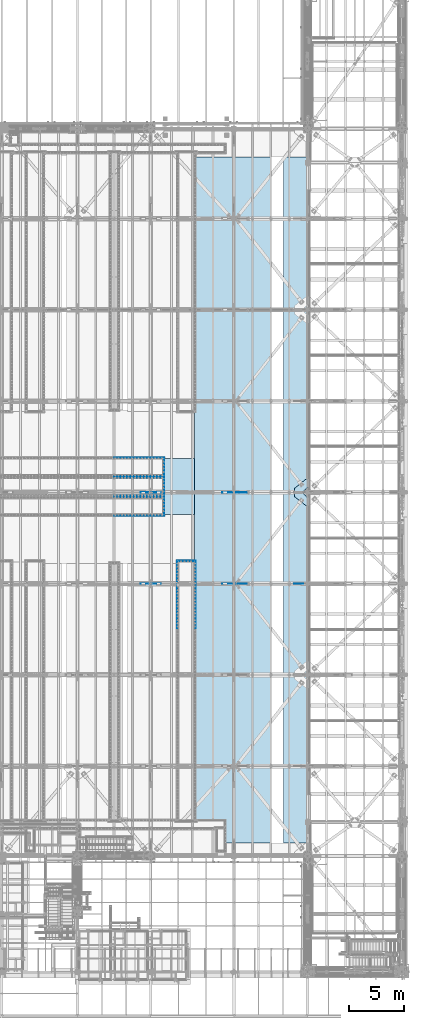
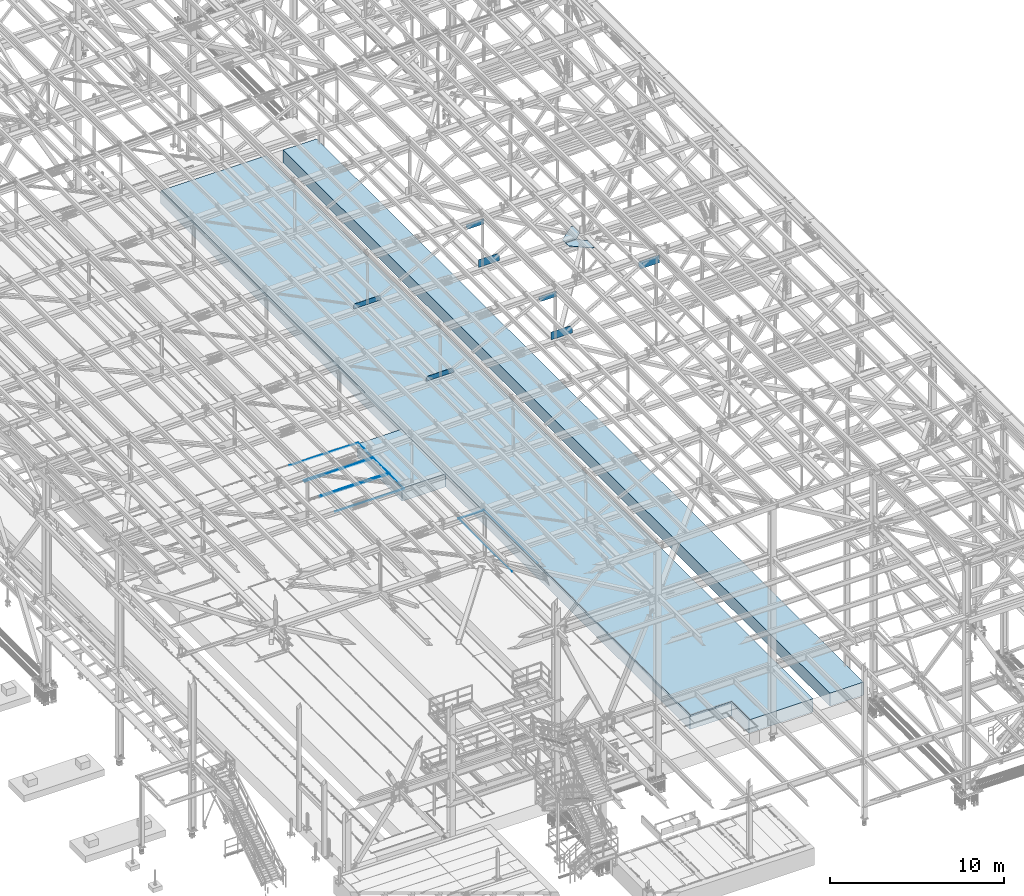
# One storey, part 2983 of 3843: 21 plates, 3 slabs, 23 elements without a shape of their own.
"""IFC2X3 building model written with IfcOpenShell, lengths in millimetres."""

from ifc_helpers import new_model, si_unit, frame, origin_with_axes, place, context, subcontext, project, spatial, faceted_brep, material, type_object, element, aggregate, save


model = new_model("IFC2X3")

# Units and contexts
model_context = context("Model", 3, precision=1e-05, world=origin_with_axes())
body_context = subcontext(model_context, "Body", "Model", "MODEL_VIEW")
ifc_project = project(units=[si_unit("LENGTHUNIT", "METRE", prefix="MILLI"), si_unit("AREAUNIT", "SQUARE_METRE"), si_unit("VOLUMEUNIT", "CUBIC_METRE"), si_unit("MASSUNIT", "GRAM", prefix="KILO"), si_unit("TIMEUNIT", "SECOND"), si_unit("PLANEANGLEUNIT", "RADIAN"), si_unit("SOLIDANGLEUNIT", "STERADIAN"), si_unit("THERMODYNAMICTEMPERATUREUNIT", "DEGREE_CELSIUS"), si_unit("LUMINOUSINTENSITYUNIT", "LUMEN")], contexts=[model_context])

# Site, building, storey
site_placement = place(None, origin_with_axes())
site = spatial("IfcSite", under=ifc_project, at=site_placement, CompositionType="ELEMENT")
building_placement = place(site_placement, origin_with_axes())
building = spatial("IfcBuilding", under=site, at=building_placement, Name="Undefined", CompositionType="ELEMENT")
storey_placement = place(building_placement, origin_with_axes())
storey = spatial("IfcBuildingStorey", under=building, at=storey_placement, Name="Undefined", CompositionType="ELEMENT", Elevation=0.0)

# Assembly, plate
assembly_1_placement = place(storey_placement, origin_with_axes())
assembly_1 = element("IfcElementAssembly", 1, at=assembly_1_placement, inside=storey, Name="EMBED_ANGLE", AssemblyPlace="NOTDEFINED", PredefinedType="RIGID_FRAME")
ifc_material_1 = material(Name="STEEL/A36")
plate_type_1 = type_object("IfcPlateType", PredefinedType="NOTDEFINED")
plate_1_placement = place(assembly_1_placement, frame((63869.062, 60391.2939999994, 30480.0000003815), z_axis=(0.0, 1.0, 0.0), x_axis=(0.0, 0.0, -1.0)))
plate_1 = element("IfcPlate", 2, at=plate_1_placement, type_object=plate_type_1, material=ifc_material_1, Name="PLATE", context=body_context, shape_type="Brep", body=[
    faceted_brep([(20.6375000381231, -6.35000000004948, 2.5465851649642e-11), (0.0, -6.3499999046162, 0.0), (0.0, 6.34999999999854, 12.6999998092651), (25.3999996185303, 6.34999999999854, 12.6999999977998), (25.3999996185303, -1.58750000000146, 4.76249999779975), (25.3999996185266, -1.58750000000146, 1697.41849965054), (20.6374996185259, -6.34999999999854, 1702.18100000139), (3.81471181754023e-07, -6.34999999999854, 1702.181), (3.78626282326877e-07, 6.34999999999854, 1689.48099965054), (25.3999996185303, 6.34999999999854, 1689.48099965054)], [[[0, 1, 2, 3, 4]], [[0, 4, 5, 6]], [[1, 0, 6, 7]], [[2, 1, 7, 8]], [[3, 2, 8, 9]], [[4, 3, 9, 5]], [[8, 7, 6, 5, 9]]]),
])
aggregate(assembly_1, [plate_1])

assembly_2_placement = place(storey_placement, origin_with_axes())
assembly_2 = element("IfcElementAssembly", 3, at=assembly_2_placement, inside=storey, Name="EMBED_ANGLE", AssemblyPlace="NOTDEFINED", PredefinedType="RIGID_FRAME")
plate_2_placement = place(assembly_2_placement, frame((59303.4115875649, 60397.6439999965, 30480.0000025529), z_axis=(0.999999999868683, 0.0, 1.62059999202029e-05), x_axis=(1.62059999200984e-05, 0.0, -0.999999999868683)))
plate_2 = element("IfcPlate", 4, at=plate_2_placement, type_object=plate_type_1, material=ifc_material_1, Name="PLATE", context=body_context, shape_type="Brep", body=[
    faceted_brep([(0.0, -6.3499999046162, 0.0), (7.27595761418343e-12, 6.3499999046162, 0.0), (25.3999999999942, 6.34999999994034, 2.91038304567337e-11), (25.3999996185921, -1.5874999999869, 7.27595761418343e-11), (20.6375000381231, -6.35000000004948, 2.5465851649642e-11), (25.4740150924117, -1.5874999999869, 4567.23749942215), (20.7115934803587, -6.34999999999854, 4572.00018920841), (0.0740914578454976, -6.34999999999854, 4572.00058593692), (0.0738856454336201, 6.34999999999854, 4559.30041105553), (25.4738855178657, 6.34999999999854, 4559.29999942322)], [[[0, 1, 2, 3, 4]], [[4, 3, 5, 6]], [[0, 4, 6, 7]], [[1, 0, 7, 8]], [[2, 1, 8, 9]], [[3, 2, 9, 5]], [[8, 7, 6, 5, 9]]]),
])
aggregate(assembly_2, [plate_2])

assembly_3_placement = place(storey_placement, origin_with_axes())
assembly_3 = element("IfcElementAssembly", 5, at=assembly_3_placement, inside=storey, Name="EMBED_ANGLE", AssemblyPlace="NOTDEFINED", PredefinedType="RIGID_FRAME")
plate_3_placement = place(assembly_3_placement, frame((59303.4115875649, 62087.1249999965, 30480.0000025529), z_axis=(0.999999999868683, 0.0, 1.62059999202029e-05), x_axis=(1.62059999200984e-05, 0.0, -0.999999999868683)))
plate_3 = element("IfcPlate", 6, at=plate_3_placement, type_object=plate_type_1, material=ifc_material_1, Name="PLATE", context=body_context, shape_type="Brep", body=[
    faceted_brep([(25.3999996185303, -6.34999999999491, 2.91038304567337e-11), (0.0, -6.3499999046162, 0.0), (7.27595761418343e-12, 6.3499999046162, 0.0), (20.6374996185295, 6.35000000000218, -7.27595761418343e-12), (25.3999996185921, 1.58750000000146, 7.27595761418343e-11), (25.4740192314966, 1.58750000000146, 4567.23750020325), (25.4738855178766, -6.34999999999854, 4559.30000020438), (0.073885645444534, -6.34999999999854, 4559.30041183668), (0.0740914578454976, 6.34999999999854, 4572.00058593692), (20.7115934803733, 6.34999999999854, 4572.00018920841)], [[[0, 1, 2, 3, 4]], [[0, 4, 5, 6]], [[1, 0, 6, 7]], [[2, 1, 7, 8]], [[3, 2, 8, 9]], [[4, 3, 9, 5]], [[8, 7, 6, 5, 9]]]),
])
aggregate(assembly_3, [plate_3])

assembly_4_placement = place(storey_placement, origin_with_axes())
assembly_4 = element("IfcElementAssembly", 7, at=assembly_4_placement, inside=storey, Name="EMBED_ANGLE", AssemblyPlace="NOTDEFINED", PredefinedType="RIGID_FRAME")
plate_4_placement = place(assembly_4_placement, frame((63869.062, 58587.8939999994, 30480.0000003815), z_axis=(0.0, 1.0, 0.0), x_axis=(0.0, 0.0, -1.0)))
plate_4 = element("IfcPlate", 8, at=plate_4_placement, type_object=plate_type_1, material=ifc_material_1, Name="PLATE", context=body_context, shape_type="Brep", body=[
    faceted_brep([(20.6375000381231, -6.35000000004948, 2.5465851649642e-11), (0.0, -6.3499999046162, 0.0), (0.0, 6.34999999999854, 12.6999998092651), (25.3999996185303, 6.34999999999854, 12.6999999977998), (25.3999996185303, -1.58750000000146, 4.76249999779975), (25.3999996185266, -1.58750000000146, 1697.41849965054), (20.6374996185259, -6.34999999999854, 1702.18100000139), (3.81471181754023e-07, -6.34999999999854, 1702.181), (3.78626282326877e-07, 6.34999999999854, 1689.48099965054), (25.3999996185303, 6.34999999999854, 1689.48099965054)], [[[0, 1, 2, 3, 4]], [[0, 4, 5, 6]], [[1, 0, 6, 7]], [[2, 1, 7, 8]], [[3, 2, 8, 9]], [[4, 3, 9, 5]], [[8, 7, 6, 5, 9]]]),
])
aggregate(assembly_4, [plate_4])

assembly_5_placement = place(storey_placement, origin_with_axes())
assembly_5 = element("IfcElementAssembly", 9, at=assembly_5_placement, inside=storey, Name="EMBED_ANGLE", AssemblyPlace="NOTDEFINED", PredefinedType="RIGID_FRAME")
plate_5_placement = place(assembly_5_placement, frame((59303.4115875649, 58594.2439999965, 30480.0000025529), z_axis=(0.999999999868683, 0.0, 1.62059999202029e-05), x_axis=(1.62059999200984e-05, 0.0, -0.999999999868683)))
plate_5 = element("IfcPlate", 10, at=plate_5_placement, type_object=plate_type_1, material=ifc_material_1, Name="PLATE", context=body_context, shape_type="Brep", body=[
    faceted_brep([(0.0, -6.3499999046162, 0.0), (7.27595761418343e-12, 6.3499999046162, 0.0), (25.3999999999942, 6.34999999994034, 2.91038304567337e-11), (25.3999996185921, -1.5874999999869, 7.27595761418343e-11), (20.6375000381231, -6.35000000004948, 2.5465851649642e-11), (25.4740150924117, -1.5874999999869, 4567.23749942215), (20.7115934803587, -6.34999999999854, 4572.00018920841), (0.0740914578454976, -6.34999999999854, 4572.00058593692), (0.0738856454336201, 6.34999999999854, 4559.30041105553), (25.4738855178657, 6.34999999999854, 4559.29999942322)], [[[0, 1, 2, 3, 4]], [[4, 3, 5, 6]], [[0, 4, 6, 7]], [[1, 0, 7, 8]], [[2, 1, 8, 9]], [[3, 2, 9, 5]], [[8, 7, 6, 5, 9]]]),
])
aggregate(assembly_5, [plate_5])

assembly_6_placement = place(storey_placement, origin_with_axes())
assembly_6 = element("IfcElementAssembly", 11, at=assembly_6_placement, inside=storey, Name="EMBED_ANGLE", AssemblyPlace="NOTDEFINED", PredefinedType="RIGID_FRAME")
plate_6_placement = place(assembly_6_placement, frame((59303.4115875649, 60283.7249999965, 30480.0000025529), z_axis=(0.999999999868683, 0.0, 1.62059999202029e-05), x_axis=(1.62059999200984e-05, 0.0, -0.999999999868683)))
plate_6 = element("IfcPlate", 12, at=plate_6_placement, type_object=plate_type_1, material=ifc_material_1, Name="PLATE", context=body_context, shape_type="Brep", body=[
    faceted_brep([(25.3999996185303, -6.34999999999491, 2.91038304567337e-11), (0.0, -6.3499999046162, 0.0), (7.27595761418343e-12, 6.3499999046162, 0.0), (20.6374996185295, 6.35000000000218, -7.27595761418343e-12), (25.3999996185921, 1.58750000000146, 7.27595761418343e-11), (25.4740192314966, 1.58750000000146, 4567.23750020325), (25.4738855178766, -6.34999999999854, 4559.30000020438), (0.073885645444534, -6.34999999999854, 4559.30041183668), (0.0740914578454976, 6.34999999999854, 4572.00058593692), (20.7115934803733, 6.34999999999854, 4572.00018920841)], [[[0, 1, 2, 3, 4]], [[0, 4, 5, 6]], [[1, 0, 6, 7]], [[2, 1, 7, 8]], [[3, 2, 8, 9]], [[4, 3, 9, 5]], [[8, 7, 6, 5, 9]]]),
])
aggregate(assembly_6, [plate_6])

assembly_7_placement = place(storey_placement, origin_with_axes())
assembly_7 = element("IfcElementAssembly", 13, at=assembly_7_placement, inside=storey, Name="EMBED_ANGLE", AssemblyPlace="NOTDEFINED", PredefinedType="RIGID_FRAME")
plate_7_placement = place(assembly_7_placement, frame((63869.0615883789, 56784.8750000029, 30480.0000003815), z_axis=(0.0, 1.0, 0.0), x_axis=(0.0, 0.0, -1.0)))
plate_7 = element("IfcPlate", 14, at=plate_7_placement, type_object=plate_type_1, material=ifc_material_1, Name="PLATE", context=body_context, shape_type="Brep", body=[
    faceted_brep([(20.6375000381231, -6.35000000004948, 2.5465851649642e-11), (0.0, -6.3499999046162, 0.0), (0.0, 6.34999999999854, 12.6999998092651), (25.3999996185303, 6.34999999999854, 12.6999999977998), (25.3999996185303, -1.58750000000146, 4.76249999779975), (25.3999996185266, -1.58750000000146, 1697.41849965054), (20.6374996185259, -6.34999999999854, 1702.18100000139), (3.81471181754023e-07, -6.34999999999854, 1702.181), (3.78626282326877e-07, 6.34999999999854, 1689.48099965054), (25.3999996185303, 6.34999999999854, 1689.48099965054)], [[[0, 1, 2, 3, 4]], [[0, 4, 5, 6]], [[1, 0, 6, 7]], [[2, 1, 7, 8]], [[3, 2, 8, 9]], [[4, 3, 9, 5]], [[8, 7, 6, 5, 9]]]),
])
aggregate(assembly_7, [plate_7])

assembly_8_placement = place(storey_placement, origin_with_axes())
assembly_8 = element("IfcElementAssembly", 15, at=assembly_8_placement, inside=storey, Name="EMBED_ANGLE", AssemblyPlace="NOTDEFINED", PredefinedType="RIGID_FRAME")
plate_8_placement = place(assembly_8_placement, frame((65056.6071409332, 52635.1500664063, 30480.0000003815), z_axis=(1.0, 0.0, 0.0), x_axis=(0.0, 0.0, -1.0)))
plate_8 = element("IfcPlate", 16, at=plate_8_placement, type_object=plate_type_1, material=ifc_material_1, Name="PLATE", context=body_context, shape_type="Brep", body=[
    faceted_brep([(3.81471181754023e-07, 6.34999999555293, 1701.76888183631), (3.78615368390456e-07, -6.35000000440778, 1689.02774962055), (25.3999996185303, -6.35000000440778, 1689.02774962055), (25.4000000789601, 1.58749890214676, 1696.99095680546), (20.6375003659959, 6.34999999555293, 1701.76888183631), (25.3999996185303, -6.3500000000131, 12.6685752134799), (25.3999996198145, 1.58727214156534, 4.73130159008724), (20.6374996185295, 6.35000000000218, -7.27595761418343e-12), (7.27595761418343e-12, 6.3499999046162, 0.0), (2.84126144833863e-09, -6.3500000000131, 12.6685752134799)], [[[0, 1, 2, 3, 4]], [[3, 2, 5, 6]], [[4, 3, 6, 7]], [[0, 4, 7, 8]], [[1, 0, 8, 9]], [[2, 1, 9, 5]], [[8, 7, 6, 5, 9]]]),
])
aggregate(assembly_8, [plate_8])

assembly_9_placement = place(storey_placement, origin_with_axes())
assembly_9 = element("IfcElementAssembly", 17, at=assembly_9_placement, inside=storey, Name="EMBED_ANGLE", AssemblyPlace="NOTDEFINED", PredefinedType="RIGID_FRAME")
plate_9_placement = place(assembly_9_placement, frame((59303.4111759438, 56791.225, 30480.0000025529), z_axis=(0.999999999868683, 0.0, 1.62059999202029e-05), x_axis=(1.62059999200984e-05, 0.0, -0.999999999868683)))
plate_9 = element("IfcPlate", 18, at=plate_9_placement, type_object=plate_type_1, material=ifc_material_1, Name="PLATE", context=body_context, shape_type="Brep", body=[
    faceted_brep([(0.0, -6.3499999046162, 0.0), (7.27595761418343e-12, 6.3499999046162, 0.0), (25.3999999999942, 6.34999999994034, 2.91038304567337e-11), (25.3999996185921, -1.5874999999869, 7.27595761418343e-11), (20.6375000381231, -6.35000000004948, 2.5465851649642e-11), (25.4740150924117, -1.5874999999869, 4567.23749942215), (20.7115934803587, -6.34999999999854, 4572.00018920841), (0.0740914578454976, -6.34999999999854, 4572.00058593692), (0.0738856454336201, 6.34999999999854, 4559.30041105553), (25.4738855178657, 6.34999999999854, 4559.29999942322)], [[[0, 1, 2, 3, 4]], [[4, 3, 5, 6]], [[0, 4, 6, 7]], [[1, 0, 7, 8]], [[2, 1, 8, 9]], [[3, 2, 9, 5]], [[8, 7, 6, 5, 9]]]),
])
aggregate(assembly_9, [plate_9])

assembly_10_placement = place(storey_placement, origin_with_axes())
assembly_10 = element("IfcElementAssembly", 19, at=assembly_10_placement, inside=storey, Name="EMBED_ANGLE", AssemblyPlace="NOTDEFINED", PredefinedType="RIGID_FRAME")
plate_10_placement = place(assembly_10_placement, frame((59303.4111759438, 58480.706, 30480.0000025529), z_axis=(0.999999999868683, 0.0, 1.62059999202029e-05), x_axis=(1.62059999200984e-05, 0.0, -0.999999999868683)))
plate_10 = element("IfcPlate", 20, at=plate_10_placement, type_object=plate_type_1, material=ifc_material_1, Name="PLATE", context=body_context, shape_type="Brep", body=[
    faceted_brep([(25.3999996185303, -6.34999999999491, 2.91038304567337e-11), (0.0, -6.3499999046162, 0.0), (7.27595761418343e-12, 6.3499999046162, 0.0), (20.6374996185295, 6.35000000000218, -7.27595761418343e-12), (25.3999996185921, 1.58750000000146, 7.27595761418343e-11), (25.4740192314966, 1.58750000000146, 4567.23750020325), (25.4738855178766, -6.34999999999854, 4559.30000020438), (0.073885645444534, -6.34999999999854, 4559.30041183668), (0.0740914578454976, 6.34999999999854, 4572.00058593692), (20.7115934803733, 6.34999999999854, 4572.00018920841)], [[[0, 1, 2, 3, 4]], [[0, 4, 5, 6]], [[1, 0, 6, 7]], [[2, 1, 7, 8]], [[3, 2, 8, 9]], [[4, 3, 9, 5]], [[8, 7, 6, 5, 9]]]),
])
aggregate(assembly_10, [plate_10])

assembly_11_placement = place(storey_placement, origin_with_axes())
assembly_11 = element("IfcElementAssembly", 21, at=assembly_11_placement, inside=storey, Name="EMBED_ANGLE", AssemblyPlace="NOTDEFINED", PredefinedType="RIGID_FRAME")
plate_11_placement = place(assembly_11_placement, frame((66751.9620305816, 52641.5, 30480.0000003815), z_axis=(0.0, -1.0, 0.0), x_axis=(0.0, 0.0, -1.0)))
plate_11 = element("IfcPlate", 22, at=plate_11_placement, type_object=plate_type_1, material=ifc_material_1, Name="PLATE", context=body_context, shape_type="Brep", body=[
    faceted_brep([(3.81471181754023e-07, 6.34999996374245, 6184.9), (3.81471181754023e-07, -6.35000003625464, 6184.90000000001), (25.3999996185303, -6.35000003625464, 6184.90000000001), (25.3999995799313, 1.58750029788644, 6184.90000609555), (20.6374984696922, 6.34999996374245, 6184.9), (25.3999996185303, -6.35000000006403, 12.7112641409767), (25.3999996185012, 1.58746944241284, 4.80682773893932), (20.6374996185295, 6.35000000000218, -7.27595761418343e-12), (7.27595761418343e-12, 6.3499999046162, 0.0), (7.8580342233181e-10, -6.35000000006403, 12.7112641409767)], [[[0, 1, 2, 3, 4]], [[3, 2, 5, 6]], [[4, 3, 6, 7]], [[0, 4, 7, 8]], [[1, 0, 8, 9]], [[2, 1, 9, 5]], [[8, 7, 6, 5, 9]]]),
])
aggregate(assembly_11, [plate_11])

assembly_12_placement = place(storey_placement, origin_with_axes())
assembly_12 = element("IfcElementAssembly", 23, at=assembly_12_placement, inside=storey, Name="EMBED_ANGLE", AssemblyPlace="NOTDEFINED", PredefinedType="RIGID_FRAME")
plate_12_placement = place(assembly_12_placement, frame((65062.957142635, 52641.5000664063, 30480.0000003815), z_axis=(-5.10699999722418e-06, -0.999999999986959, 0.0), x_axis=(0.0, 0.0, -1.0)))
plate_12 = element("IfcPlate", 24, at=plate_12_placement, type_object=plate_type_1, material=ifc_material_1, Name="PLATE", context=body_context, shape_type="Brep", body=[
    faceted_brep([(25.3999996185303, 6.34999998807325, 6184.89987113706), (3.81471181754023e-07, 6.34999998807325, 6184.89987113706), (3.81471181754023e-07, -6.35000001190929, 6184.89987113703), (20.637498469714, -6.35000001190929, 6184.89987113703), (25.3999996185521, -1.58750068734662, 6184.89987113704), (25.3999996185303, 6.34999999996217, 12.731334147873), (7.8580342233181e-10, 6.34999999996217, 12.731334147873), (0.0, -6.3499999046162, 0.0), (20.6375000381231, -6.35000000004948, 2.5465851649642e-11), (25.3999996185303, -1.61906264965364, 4.76235011019162)], [[[0, 1, 2, 3, 4]], [[1, 0, 5, 6]], [[2, 1, 6, 7]], [[3, 2, 7, 8]], [[4, 3, 8, 9]], [[0, 4, 9, 5]], [[8, 7, 6, 5, 9]]]),
])
aggregate(assembly_12, [plate_12])

assembly_13_placement = place(storey_placement, origin_with_axes())
assembly_13 = element("IfcElementAssembly", 25, at=assembly_13_placement, inside=storey, Name="PLATE", AssemblyPlace="NOTDEFINED", PredefinedType="RIGID_FRAME")
ifc_material_2 = material(Name="STEEL/A572-50")
plate_type_2 = type_object("IfcPlateType", PredefinedType="NOTDEFINED")
plate_13_placement = place(assembly_13_placement, frame((77008.0375222877, 59397.8999848818, 42232.2625), z_axis=(-1.0, 0.0, 0.0), x_axis=(0.0, 1.0, 0.0)))
plate_13 = element("IfcPlate", 26, at=plate_13_placement, type_object=plate_type_2, material=ifc_material_2, Name="PLATE", context=body_context, shape_type="Brep", body=[
    faceted_brep([(0.0, -14.2874999999985, 0.0), (-475.456250002258, -14.2874999999985, 477.837502193986), (-475.456250002258, 14.2874999999985, 477.837502193986), (0.0, 14.2874999999985, 0.0), (-475.456250002258, -14.2874999999985, 1214.4375021945), (-475.456250002258, 14.2874999999985, 1214.4375021945), (-125.919147861619, -14.2874999999985, 1214.43750308026), (-125.919147861619, 14.2874999999985, 1214.43750308026), (736.600000090519, -14.2874999999985, 147.637499993114), (736.600000090519, 14.2874999999985, 147.637499993114), (736.599999940488, -14.2874999999985, 0.0), (736.599999940488, 14.2874999999985, 0.0)], [[[0, 1, 2, 3]], [[1, 4, 5, 2]], [[4, 6, 7, 5]], [[6, 8, 9, 7]], [[8, 10, 11, 9]], [[10, 0, 3, 11]], [[5, 7, 9, 11, 3, 2]], [[10, 8, 6, 4, 1, 0]]]),
])
aggregate(assembly_13, [plate_13])

assembly_14_placement = place(storey_placement, origin_with_axes())
assembly_14 = element("IfcElementAssembly", 27, at=assembly_14_placement, inside=storey, Name="PLATE", AssemblyPlace="NOTDEFINED", PredefinedType="RIGID_FRAME")
plate_14_placement = place(assembly_14_placement, frame((77008.037519207, 58432.6999848772, 42232.2625), z_axis=(-1.0, 0.0, 0.0), x_axis=(0.0, -1.0, 0.0)))
plate_14 = element("IfcPlate", 28, at=plate_14_placement, type_object=plate_type_2, material=ifc_material_2, Name="PLATE", context=body_context, shape_type="Brep", body=[
    faceted_brep([(0.0, -14.2874999999985, 0.0), (-475.456250002258, -14.2874999999985, 477.837502193986), (-475.456250002258, 14.2874999999985, 477.837502193986), (0.0, 14.2874999999985, 0.0), (-475.456250002258, -14.2874999999985, 1214.4375021945), (-475.456250002258, 14.2874999999985, 1214.4375021945), (-103.221274751806, -14.2874999999985, 1214.43749780451), (-103.221274751806, 14.2874999999985, 1214.43749780451), (736.600000090519, -14.2874999999985, 147.637499993114), (736.600000090519, 14.2874999999985, 147.637499993114), (736.599999940488, -14.2874999999985, 0.0), (736.599999940488, 14.2874999999985, 0.0)], [[[0, 1, 2, 3]], [[1, 4, 5, 2]], [[4, 6, 7, 5]], [[6, 8, 9, 7]], [[8, 10, 11, 9]], [[10, 0, 3, 11]], [[5, 7, 9, 11, 3, 2]], [[10, 8, 6, 4, 1, 0]]]),
])
aggregate(assembly_14, [plate_14])

assembly_15_placement = place(storey_placement, origin_with_axes())
assembly_15 = element("IfcElementAssembly", 29, at=assembly_15_placement, inside=storey, Name="BEAM", AssemblyPlace="NOTDEFINED", PredefinedType="RIGID_FRAME")
plate_type_3 = type_object("IfcPlateType", PredefinedType="NOTDEFINED")
plate_15_placement = place(assembly_15_placement, frame((71423.0407854026, 58915.3, 42532.3048757002), z_axis=(0.000189087000020663, 0.0, 0.999999982123053), x_axis=(-0.999999982123053, 0.0, 0.000189087000025738)))
plate_15 = element("IfcPlate", 30, at=plate_15_placement, type_object=plate_type_3, material=ifc_material_2, Name="PLATE", context=body_context, shape_type="Brep", body=[
    faceted_brep([(0.0, -9.52500000000146, 0.0), (-1.19325704872608e-09, -9.52500000000146, 272.018172355572), (-1.19325704872608e-09, 9.52500000000146, 272.018172355572), (0.0, 9.52500000000146, 0.0), (150.207742872095, -9.52500000000146, 537.236336314461), (150.207742872095, 9.52500000000146, 537.236336314461), (1398.51735042044, -9.52500000000146, 537.236336310845), (1398.51735042044, 9.52500000000146, 537.236336310845), (1398.51735042283, -9.52500000000146, -4.06726030632854e-09), (1398.51735042283, 9.52500000000146, -4.06726030632854e-09)], [[[0, 1, 2, 3]], [[1, 4, 5, 2]], [[4, 6, 7, 5]], [[6, 8, 9, 7]], [[8, 0, 3, 9]], [[5, 7, 9, 3, 2]], [[8, 6, 4, 1, 0]]]),
])
aggregate(assembly_15, [plate_15])

assembly_16_placement = place(storey_placement, origin_with_axes())
assembly_16 = element("IfcElementAssembly", 31, at=assembly_16_placement, inside=storey, Name="BEAM", AssemblyPlace="NOTDEFINED", PredefinedType="RIGID_FRAME")
plate_type_4 = type_object("IfcPlateType", PredefinedType="NOTDEFINED")
plate_16_placement = place(assembly_16_placement, frame((70370.2239296506, 58915.3, 45840.8628900239), z_axis=(0.0210423920075118, 0.0, -0.999778584356858), x_axis=(-0.999778584356858, 0.0, -0.0210423920075088)))
plate_16 = element("IfcPlate", 32, at=plate_16_placement, type_object=plate_type_4, material=ifc_material_2, Name="PLATE", context=body_context, shape_type="Brep", body=[
    faceted_brep([(0.0, -9.52500000000146, 0.0), (7.49736213505093, -9.52500000000146, 378.809671376701), (7.49736213505093, 9.52500000000146, 378.809671376701), (0.0, 9.52500000000146, 0.0), (1072.73514739941, -9.52500000000146, 356.387583692478), (1072.73514739941, 9.52500000000146, 356.387583692478), (1178.64157550852, -9.52500000000146, 125.520023338257), (1178.64157550852, 9.52500000000146, 125.520023338257), (1178.64157550936, -9.52500000000146, -8.94942786544561e-09), (1178.64157550936, 9.52500000000146, -8.94942786544561e-09)], [[[0, 1, 2, 3]], [[1, 4, 5, 2]], [[4, 6, 7, 5]], [[6, 8, 9, 7]], [[8, 0, 3, 9]], [[5, 7, 9, 3, 2]], [[8, 6, 4, 1, 0]]]),
])
aggregate(assembly_16, [plate_16])

# Assembly, plates
assembly_17_placement = place(storey_placement, origin_with_axes())
assembly_17 = element("IfcElementAssembly", 33, at=assembly_17_placement, inside=storey, Name="BEAM", AssemblyPlace="NOTDEFINED", PredefinedType="RIGID_FRAME")
plate_17_placement = place(assembly_17_placement, frame((70370.2266121063, 50558.7, 45836.8400614558), z_axis=(0.0209237229988212, 0.0, -0.999781074943844), x_axis=(-0.999781074943844, 0.0, -0.0209237229988253)))
plate_17 = element("IfcPlate", 34, at=plate_17_placement, type_object=plate_type_4, material=ifc_material_2, Name="PLATE", context=body_context, shape_type="Brep", body=[
    faceted_brep([(0.0, -9.52500000000146, 0.0), (7.45257887804473, -9.52500000000146, 378.690789820255), (7.45257887804473, 9.52500000000146, 378.690789820255), (0.0, 9.52500000000146, 0.0), (1072.71180081816, -9.52500000000146, 356.394743734098), (1072.71180081816, 9.52500000000146, 356.394743734098), (1178.6238194461, -9.52500000000146, 125.52974722629), (1178.6238194461, 9.52500000000146, 125.52974722629), (1178.6238194473, -9.52500000000146, 1.10594555735588e-08), (1178.6238194473, 9.52500000000146, 1.10594555735588e-08)], [[[0, 1, 2, 3]], [[1, 4, 5, 2]], [[4, 6, 7, 5]], [[6, 8, 9, 7]], [[8, 0, 3, 9]], [[5, 7, 9, 3, 2]], [[8, 6, 4, 1, 0]]]),
])
plate_type_5 = type_object("IfcPlateType", PredefinedType="NOTDEFINED")
plate_18_placement = place(assembly_17_placement, frame((77196.9499999754, 50558.7, 45974.8955942044), z_axis=(0.0196260750008078, 0.0, -0.999807390040733), x_axis=(-0.999807390040733, 0.0, -0.0196260750008018)))
plate_18 = element("IfcPlate", 35, at=plate_18_placement, type_object=plate_type_5, material=ifc_material_2, Name="PLATE", context=body_context, shape_type="Brep", body=[
    faceted_brep([(0.0, -9.52500000000146, 0.0), (10.8531702655164, -9.52500000000146, 552.890973601643), (10.8531702655164, 9.52500000000146, 552.890973601643), (0.0, 9.52500000000146, 0.0), (1255.4881230696, -9.52500000000146, 528.458968538704), (1255.4881230696, 9.52500000000146, 528.458968538704), (1400.38772451055, -9.52500000000146, 260.303889036331), (1400.38772451055, 9.52500000000146, 260.303889036331), (1400.38772451077, -9.52500000000146, -8.73842509463429e-09), (1400.38772451077, 9.52500000000146, -8.73842509463429e-09)], [[[0, 1, 2, 3]], [[1, 4, 5, 2]], [[4, 6, 7, 5]], [[6, 8, 9, 7]], [[8, 0, 3, 9]], [[5, 7, 9, 3, 2]], [[8, 6, 4, 1, 0]]]),
])
aggregate(assembly_17, [plate_18, plate_17])

# Assembly, plate
assembly_18_placement = place(storey_placement, origin_with_axes())
assembly_18 = element("IfcElementAssembly", 36, at=assembly_18_placement, inside=storey, Name="BEAM", AssemblyPlace="NOTDEFINED", PredefinedType="RIGID_FRAME")
plate_type_6 = type_object("IfcPlateType", PredefinedType="NOTDEFINED")
plate_19_placement = place(assembly_18_placement, frame((63552.0653952486, 50558.7, 42525.8479307238), z_axis=(-0.00121008799981064, 0.0, 0.999999267843248), x_axis=(-0.999999267843248, 0.0, -0.00121008799981153)))
plate_19 = element("IfcPlate", 37, at=plate_19_placement, type_object=plate_type_6, material=ifc_material_2, Name="PLATE", context=body_context, shape_type="Brep", body=[
    faceted_brep([(0.0, -9.52500000000146, 0.0), (-3.12866177409887e-10, -9.52500000000146, 145.654037935084), (-3.12866177409887e-10, 9.52500000000146, 145.654037935084), (0.0, 9.52500000000146, 0.0), (89.3184747597115, -9.52500000000146, 330.636089736487), (89.3184747597115, 9.52500000000146, 330.636089736487), (1738.20001134388, -9.52500000000146, 330.636089740125), (1738.20001134388, 9.52500000000146, 330.636089740125), (1818.28048947, -9.52500000000146, 171.891143931309), (1818.28048947, 9.52500000000146, 171.891143931309), (1818.28048947039, -9.52500000000146, 4.00177668780088e-09), (1818.28048947039, 9.52500000000146, 4.00177668780088e-09)], [[[0, 1, 2, 3]], [[1, 4, 5, 2]], [[4, 6, 7, 5]], [[6, 8, 9, 7]], [[8, 10, 11, 9]], [[10, 0, 3, 11]], [[5, 7, 9, 11, 3, 2]], [[10, 8, 6, 4, 1, 0]]]),
])
aggregate(assembly_18, [plate_19])

assembly_19_placement = place(storey_placement, origin_with_axes())
assembly_19 = element("IfcElementAssembly", 38, at=assembly_19_placement, inside=storey, Name="BEAM", AssemblyPlace="NOTDEFINED", PredefinedType="RIGID_FRAME")
plate_type_7 = type_object("IfcPlateType", PredefinedType="NOTDEFINED")
plate_20_placement = place(assembly_19_placement, frame((71426.6168959358, 50558.7, 42528.1312241889), z_axis=(0.000305732000080752, 0.0, 0.999999953263971), x_axis=(-0.999999953263971, 0.0, 0.000305732000079087)))
plate_20 = element("IfcPlate", 39, at=plate_20_placement, type_object=plate_type_7, material=ifc_material_2, Name="PLATE", context=body_context, shape_type="Brep", body=[
    faceted_brep([(0.0, -9.52500000000146, 0.0), (2.7648638933897e-10, -9.52500000000146, 274.073781102423), (2.7648638933897e-10, 9.52500000000146, 274.073781102423), (0.0, 9.52500000000146, 0.0), (150.215615431036, -9.52500000000146, 539.287487463422), (150.215615431036, 9.52500000000146, 539.287487463422), (1414.8567239628, -9.52500000000146, 539.287487462192), (1414.8567239628, 9.52500000000146, 539.287487462192), (1414.85672396229, -9.52500000000146, -1.3606040738523e-09), (1414.85672396229, 9.52500000000146, -1.3606040738523e-09)], [[[0, 1, 2, 3]], [[1, 4, 5, 2]], [[4, 6, 7, 5]], [[6, 8, 9, 7]], [[8, 0, 3, 9]], [[5, 7, 9, 3, 2]], [[8, 6, 4, 1, 0]]]),
])
aggregate(assembly_19, [plate_20])

assembly_20_placement = place(storey_placement, origin_with_axes())
assembly_20 = element("IfcElementAssembly", 40, at=assembly_20_placement, inside=storey, Name="BEAM", AssemblyPlace="NOTDEFINED", PredefinedType="RIGID_FRAME")
plate_type_8 = type_object("IfcPlateType", PredefinedType="NOTDEFINED")
plate_21_placement = place(assembly_20_placement, frame((63556.0142556726, 58915.3, 42529.0860052179), z_axis=(-0.00133192499998404, 0.0, 0.999999112987504), x_axis=(-0.999999112987504, 0.0, -0.00133192499998534)))
plate_21 = element("IfcPlate", 41, at=plate_21_placement, type_object=plate_type_8, material=ifc_material_2, Name="PLATE", context=body_context, shape_type="Brep", body=[
    faceted_brep([(0.0, -9.52500000000146, 0.0), (-1.23691279441118e-10, -9.52500000000146, 147.542115061529), (-1.23691279441118e-10, 9.52500000000146, 147.542115061529), (0.0, 9.52500000000146, 0.0), (89.4156547729071, -9.52500000000146, 332.738370360225), (89.4156547729071, 9.52500000000146, 332.738370360225), (1746.28501610601, -9.52500000000146, 332.73837036144), (1746.28501610601, 9.52500000000146, 332.73837036144), (1826.36945078514, -9.52500000000146, 173.995422291919), (1826.36945078514, 9.52500000000146, 173.995422291919), (1826.36945078527, -9.52500000000146, 1.35332811623812e-09), (1826.36945078527, 9.52500000000146, 1.35332811623812e-09)], [[[0, 1, 2, 3]], [[1, 4, 5, 2]], [[4, 6, 7, 5]], [[6, 8, 9, 7]], [[8, 10, 11, 9]], [[10, 0, 3, 11]], [[5, 7, 9, 11, 3, 2]], [[10, 8, 6, 4, 1, 0]]]),
])
aggregate(assembly_20, [plate_21])

# Assembly, slab
assembly_21_placement = place(storey_placement, origin_with_axes())
assembly_21 = element("IfcElementAssembly", 42, at=assembly_21_placement, inside=storey, Name="SLAB", AssemblyPlace="NOTDEFINED", PredefinedType="REINFORCEMENT_UNIT")
ifc_material_3 = material(Name="CONCRETE/3000")
slab_type_1 = type_object("IfcSlabType", PredefinedType="NOTDEFINED")
slab_1_placement = place(assembly_21_placement, frame((63786.512, 62004.575, 30022.8), z_axis=(1.0, 0.0, 0.0), x_axis=(0.0, -1.0, 0.0)))
slab_1 = element("IfcSlab", 43, at=slab_1_placement, type_object=slab_type_1, material=ifc_material_3, Name="SLAB", PredefinedType="FLOOR", context=body_context, shape_type="Brep", body=[
    faceted_brep([(3530.21900007602, -457.200000000001, 0.0), (3530.21899999988, -431.800005019068, -0.000649149500532076), (3530.21899997327, -431.800005019068, 76.1993508505257), (3530.21900004941, -457.200000000001, 76.1993508505257), (5130.7998046875, -431.800000215193, 76.1995781313672), (5130.7998046875, -431.800000215193, 0.0), (5130.7998046875, -457.200000000001, 76.1995781313672), (3404.07125841757, -431.800000000007, -7.27595761418343e-12), (3404.07125841756, -431.800000000007, 76.1999999999898), (1727.20000002088, -431.800000000007, 76.2000000000335), (1727.20000002089, -431.800000000007, 7.27595761418343e-12), (3404.07125841756, -457.200000000001, 76.1999999999898), (3404.07125841757, -457.200000000001, 0.0), (1727.20000002088, -457.200000000001, 76.2000000000335), (1727.20000002089, -457.200000000001, 0.0), (1600.67125841758, -431.799999999999, 0.0), (1600.67125841758, -431.799999999999, 76.1999999999971), (-7.27595761418343e-12, -431.799999999999, 76.2000000000262), (0.0, -431.800000000287, 0.0), (1600.67125841758, -457.200000000001, 76.1999999999971), (1600.67125841758, -457.200000000001, 0.0), (0.0, -457.200000000001, 76.2000000000262), (0.0, -457.200000000001, 2882.89990234375), (0.0, 457.200000000001, 2882.89990234375), (0.0, 457.200000000001, 0.0), (5130.7998046875, 457.200000000001, 2882.89990234375), (5130.7998046875, 457.200000000001, 0.0), (5130.7998046875, -457.200000000001, 2882.89990234375)], [[[0, 1, 2, 3]], [[4, 2, 1, 5]], [[6, 3, 2, 4]], [[7, 8, 9, 10]], [[11, 8, 7, 12]], [[13, 9, 8, 11]], [[14, 10, 9, 13]], [[15, 16, 17, 18]], [[19, 16, 15, 20]], [[21, 17, 16, 19]], [[22, 23, 24, 18, 17, 21]], [[25, 26, 24, 23]], [[22, 27, 25, 23]], [[5, 26, 25, 27, 6, 4]], [[0, 12, 7, 10, 14, 20, 15, 18, 24, 26, 5, 1]], [[27, 22, 21, 19, 20, 14, 13, 11, 12, 0, 3, 6]]]),
])
aggregate(assembly_21, [slab_1])

assembly_22_placement = place(storey_placement, origin_with_axes())
assembly_22 = element("IfcElementAssembly", 44, at=assembly_22_placement, inside=storey, Name="SLAB", AssemblyPlace="NOTDEFINED", PredefinedType="REINFORCEMENT_UNIT")
slab_type_2 = type_object("IfcSlabType", PredefinedType="NOTDEFINED")
slab_2_placement = place(assembly_22_placement, frame((66669.412, 26825.575, 30022.8), z_axis=(0.0, 1.0, 0.0), x_axis=(1.0, 0.0, 0.0)))
slab_2 = element("IfcSlab", 45, at=slab_2_placement, type_object=slab_type_2, material=ifc_material_3, Name="SLAB", PredefinedType="FLOOR", context=body_context, shape_type="Brep", body=[
    faceted_brep([(76.1999999999971, -432.196872905261, 2079.62490287595), (76.2000008424657, -431.800000762945, 25803.22461375), (8.42468580231071e-07, -431.800000762945, 25803.22461375), (-0.000208821118576452, -432.19687290701, 2079.58732970622), (76.2000008424657, -457.19956414359, 25803.2250386593), (76.200000080993, -457.200000010471, 2079.58749285336), (0.0, -457.200000000001, 25803.2250386666), (0.0, -431.80000000057, 62788.80078125), (1.10594555735588e-09, -431.80000000057, 39423.8478007813), (76.2000003905268, -431.800000000025, 39423.8478007813), (76.2000003905268, -431.800000000025, 62788.80078125), (76.1999999999825, -457.200000381476, 39423.8478007813), (0.0, -457.200000000001, 39423.8478007813), (76.1999999999825, -457.200000381476, 62788.80078125), (7003.0341796875, -457.200000000001, 62788.80078125), (7003.0341796875, 457.200000000001, 62788.80078125), (0.0, 457.200000000001, 62788.80078125), (2743.19995117188, 457.200000000001, 2003.425), (2743.19995117188, 457.200000000001, 0.0), (2743.19995117188, -431.814209336986, 0.0), (2743.19995117188, -431.81061118357, 2003.425), (2819.39993108273, -431.814210098993, -4.51360247097909e-05), (2819.39991861457, -431.81047509038, 2079.62495486398), (2743.19990549322, -431.810474328373, 2079.62495440685), (-0.00021190382540226, -431.827766505452, 2079.58732970618), (0.0, -431.800000603787, 2003.425), (0.0, 457.200000000001, 2003.425), (7003.0341796875, 457.200000000001, 0.0), (7003.0341796875, -457.200000000001, 0.0), (2819.3999310845, -457.200000000001, 0.0), (2819.39991861633, -457.196264999275, 2079.62500045688), (2743.19978810185, -457.200000376921, 2079.59320290424)], [[[0, 1, 2, 3]], [[4, 1, 0, 5]], [[6, 2, 1, 4]], [[7, 8, 9, 10]], [[11, 9, 8, 12]], [[13, 10, 9, 11]], [[14, 15, 16, 7, 10, 13]], [[17, 18, 19, 20]], [[19, 21, 22, 23, 20]], [[23, 24, 25, 20]], [[26, 17, 20, 25]], [[16, 15, 27, 18, 17, 26]], [[14, 28, 27, 15]], [[19, 18, 27, 28, 29, 21]], [[30, 22, 21, 29]], [[22, 30, 31, 23]], [[3, 24, 23, 31, 5, 0]], [[12, 8, 7, 16, 26, 25, 24, 3, 2, 6]], [[31, 30, 29, 28, 14, 13, 11, 12, 6, 4, 5]]]),
])
aggregate(assembly_22, [slab_2])

assembly_23_placement = place(storey_placement, origin_with_axes())
assembly_23 = element("IfcElementAssembly", 46, at=assembly_23_placement, inside=storey, Name="SLAB", AssemblyPlace="NOTDEFINED", PredefinedType="REINFORCEMENT_UNIT")
slab_type_3 = type_object("IfcSlabType", PredefinedType="NOTDEFINED")
slab_3_placement = place(assembly_23_placement, frame((74790.046, 26825.575, 30022.8), z_axis=(0.0, 1.0, 0.0), x_axis=(1.0, 0.0, 0.0)))
slab_3 = element("IfcSlab", 47, at=slab_3_placement, type_object=slab_type_3, material=ifc_material_3, Name="SLAB", PredefinedType="FLOOR", context=body_context, shape_type="Brep", body=[
    faceted_brep([(0.0, -457.200000000001, 0.0), (0.0, -457.200000000001, 62788.80078125), (0.0, 457.200000000001, 62788.80078125), (0.0, 457.200000000001, 0.0), (2222.75390625, -457.200000000001, 62788.80078125), (2222.75390625, 457.200000000001, 62788.80078125), (2222.75390625, -457.200000000001, 0.0), (2222.75390625, 457.200000000001, 0.0)], [[[0, 1, 2, 3]], [[1, 4, 5, 2]], [[4, 6, 7, 5]], [[6, 0, 3, 7]], [[5, 7, 3, 2]], [[6, 4, 1, 0]]]),
])
aggregate(assembly_23, [slab_3])

save(model, "model.ifc")
